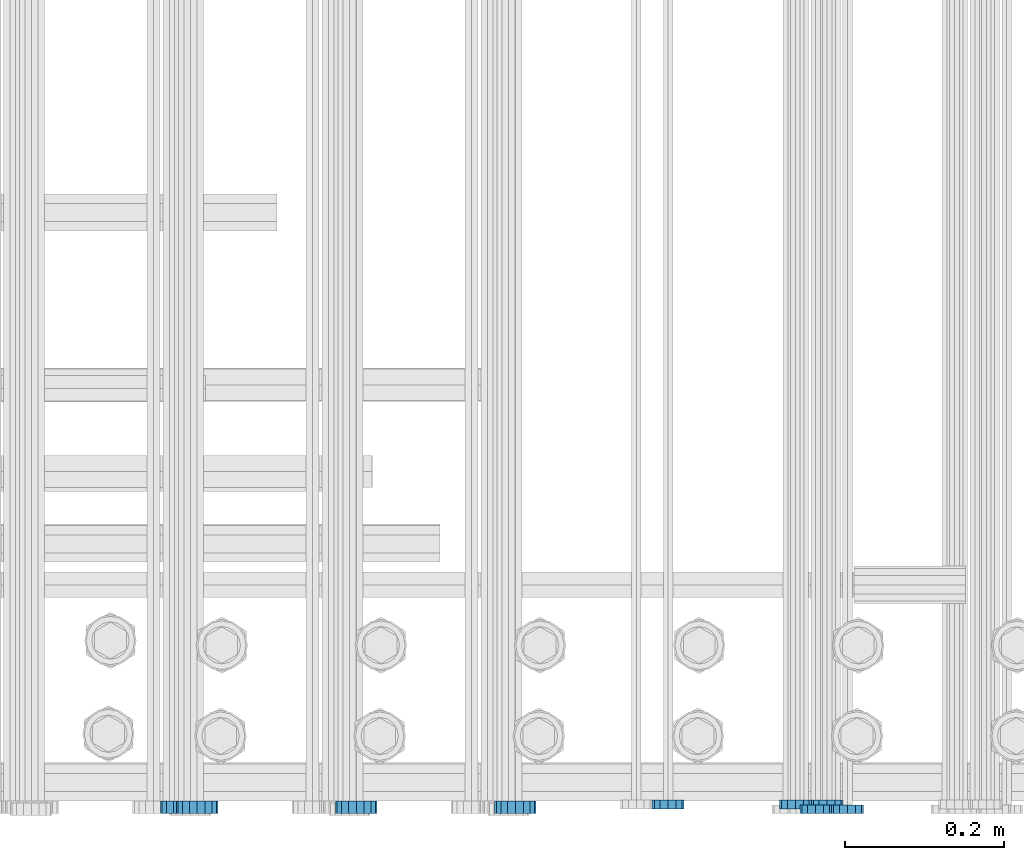
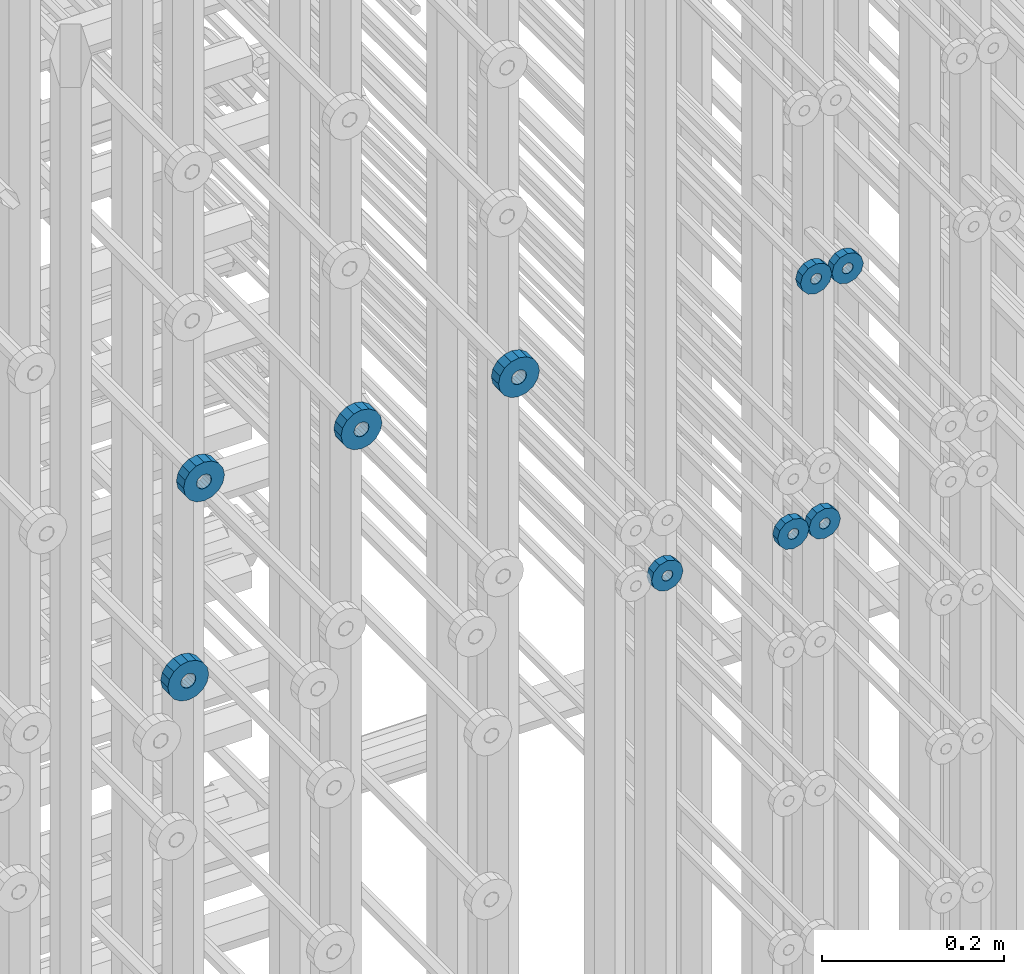
# One storey, part 121 of 177: 9 beams.
"""IFC2X3 building model written with IfcOpenShell, lengths in millimetres."""

from ifc_helpers import new_model, si_unit, frame, origin_with_axes, place, context, subcontext, project, spatial, faceted_brep, material, type_object, element, save


model = new_model("IFC2X3")

# Units and contexts
model_context_1 = context("Model", 3, precision=1e-05, world=origin_with_axes())
model_context_2 = context("Model", 3, precision=1e-05, world=origin_with_axes())
body_context = subcontext(model_context_2, "Body", "Model", "MODEL_VIEW")
ifc_project = project(units=[si_unit("LENGTHUNIT", "METRE", prefix="MILLI"), si_unit("AREAUNIT", "SQUARE_METRE"), si_unit("VOLUMEUNIT", "CUBIC_METRE"), si_unit("MASSUNIT", "GRAM", prefix="KILO"), si_unit("TIMEUNIT", "SECOND"), si_unit("PLANEANGLEUNIT", "RADIAN"), si_unit("SOLIDANGLEUNIT", "STERADIAN"), si_unit("THERMODYNAMICTEMPERATUREUNIT", "DEGREE_CELSIUS"), si_unit("LUMINOUSINTENSITYUNIT", "LUMEN")], contexts=[model_context_1])

# Site, building, storey
site_placement = place(None, origin_with_axes())
site = spatial("IfcSite", under=ifc_project, at=site_placement, CompositionType="ELEMENT")
building_placement = place(site_placement, origin_with_axes())
building = spatial("IfcBuilding", under=site, at=building_placement, Name="Undefined", CompositionType="ELEMENT")
storey_placement = place(building_placement, origin_with_axes())
storey = spatial("IfcBuildingStorey", under=building, at=storey_placement, Name="Undefined", CompositionType="ELEMENT", Elevation=0.0)

# Beams
ifc_material = material(Name="STEEL/Steel_Undefined")
beam_type_1 = type_object("IfcBeamType", PredefinedType="NOTDEFINED")
beam_1_placement = place(storey_placement, frame((2031761.99847313, 6205070.98588033, 21128.9868114202), z_axis=(0.0, 0.0, -1.0), x_axis=(0.0, -1.0, 0.0)))
element("IfcBeam", 1, at=beam_1_placement, inside=storey, type_object=beam_type_1, material=ifc_material, context=body_context, shape_type="Brep", body=[
    faceted_brep([(-3.63797880709171e-12, -7.0, -2.3283064365387e-10), (-8.62348444298797e-13, -6.06217782649107, 3.5), (10.9999999999964, -6.06217782665044, 3.49999999976717), (10.9999999999964, -7.0, -2.3283064365387e-10), (-3.63797880709171e-12, -3.5, 6.06217782618478), (11.0, -3.5, 6.06217782618478), (-1.72469688859759e-12, 0.0, 7.0), (11.0, 0.0, 6.99999999976717), (-3.63797880709171e-12, 3.5, 6.06217782618478), (11.0, 3.5, 6.06217782618478), (-8.62348444298795e-13, 6.06217782649107, 3.5), (10.9999999999964, 6.06217782665044, 3.49999999976717), (-3.63797880709171e-12, 7.0, -2.3283064365387e-10), (10.9999999999964, 7.0, -2.3283064365387e-10), (8.62348444298797e-13, 6.06217782649107, -3.5), (10.9999999999964, 6.06217782665044, -3.50000000023283), (-3.63797880709171e-12, 3.5, -6.06217782665044), (10.9999999999964, 3.5, -6.06217782665044), (1.72469688859759e-12, -2.72004641033163e-15, -7.0), (10.9999999999964, 0.0, -7.00000000023283), (-3.63797880709171e-12, -3.5, -6.06217782665044), (10.9999999999964, -3.5, -6.06217782665044), (8.62348444298796e-13, -6.06217782649107, -3.5), (10.9999999999964, -6.06217782665044, -3.50000000023283), (0.0, -20.0000000009313, 0.0), (0.0, -17.320508075878, -10.0), (10.9999999999964, -17.320508075878, -10.0000000002328), (10.9999999999964, -20.0, -2.3283064365387e-10), (0.0, -10.0000000009313, -17.3205080756452), (11.0, -10.0, -17.320508075878), (0.0, -1.86264514923096e-09, -19.9999999998836), (10.9999999999964, 0.0, -20.0000000002328), (0.0, 9.99999999906868, -17.3205080755288), (11.0, 10.0, -17.320508075878), (0.0, 17.320508075878, -10.0), (10.9999999999964, 17.320508075878, -10.0000000002328), (0.0, 19.9999999990687, 0.0), (10.9999999999964, 20.0, -2.3283064365387e-10), (0.0, 17.3205080740154, 10.0), (11.0, 17.320508075878, 9.99999999976717), (0.0, 9.99999999906868, 17.3205080757616), (10.9999999999964, 10.0, 17.3205080754124), (0.0, 0.0, 20.0000000001164), (10.9999999999964, 0.0, 19.9999999997672), (0.0, -10.0000000009313, 17.3205080757616), (10.9999999999964, -10.0, 17.3205080754124), (0.0, -17.3205080777407, 10.0000000001164), (11.0, -17.320508075878, 9.99999999976717)], [[[0, 1, 2, 3]], [[1, 4, 5, 2]], [[4, 6, 7, 5]], [[6, 8, 9, 7]], [[8, 10, 11, 9]], [[10, 12, 13, 11]], [[12, 14, 15, 13]], [[14, 16, 17, 15]], [[16, 18, 19, 17]], [[18, 20, 21, 19]], [[20, 22, 23, 21]], [[22, 0, 3, 23]], [[24, 25, 26, 27]], [[25, 28, 29, 26]], [[28, 30, 31, 29]], [[30, 32, 33, 31]], [[32, 34, 35, 33]], [[34, 36, 37, 35]], [[36, 38, 39, 37]], [[38, 40, 41, 39]], [[40, 42, 43, 41]], [[42, 44, 45, 43]], [[44, 46, 47, 45]], [[46, 24, 27, 47]], [[29, 31, 33, 35, 37, 39, 41, 43, 45, 47, 27, 26], [5, 7, 9, 11, 13, 15, 17, 19, 21, 23, 3, 2]], [[46, 44, 42, 40, 38, 36, 34, 32, 30, 28, 25, 24], [22, 20, 18, 16, 14, 12, 10, 8, 6, 4, 1, 0]]]),
])
beam_2_placement = place(storey_placement, frame((2031721.99847313, 6205070.98588033, 21128.9868114202), z_axis=(0.0, 0.0, -1.0), x_axis=(0.0, -1.0, 0.0)))
element("IfcBeam", 2, at=beam_2_placement, inside=storey, type_object=beam_type_1, material=ifc_material, context=body_context, shape_type="Brep", body=[
    faceted_brep([(-3.63797880709171e-12, -7.0, -2.3283064365387e-10), (-8.62348444298797e-13, -6.06217782649107, 3.5), (10.9999999999964, -6.06217782665044, 3.49999999976717), (10.9999999999964, -7.0, -2.3283064365387e-10), (-3.63797880709171e-12, -3.5, 6.06217782618478), (11.0, -3.5, 6.06217782618478), (-1.72469688859759e-12, 0.0, 7.0), (11.0, 0.0, 6.99999999976717), (-3.63797880709171e-12, 3.5, 6.06217782618478), (11.0, 3.5, 6.06217782618478), (-8.62348444298795e-13, 6.06217782649107, 3.5), (10.9999999999964, 6.06217782665044, 3.49999999976717), (-3.63797880709171e-12, 7.0, -2.3283064365387e-10), (10.9999999999964, 7.0, -2.3283064365387e-10), (8.62348444298797e-13, 6.06217782649107, -3.5), (10.9999999999964, 6.06217782665044, -3.50000000023283), (-3.63797880709171e-12, 3.5, -6.06217782665044), (10.9999999999964, 3.5, -6.06217782665044), (1.72469688859759e-12, -2.72004641033163e-15, -7.0), (10.9999999999964, 0.0, -7.00000000023283), (-3.63797880709171e-12, -3.5, -6.06217782665044), (10.9999999999964, -3.5, -6.06217782665044), (8.62348444298796e-13, -6.06217782649107, -3.5), (10.9999999999964, -6.06217782665044, -3.50000000023283), (0.0, -20.0000000009313, 0.0), (0.0, -17.320508075878, -10.0), (10.9999999999964, -17.320508075878, -10.0000000002328), (10.9999999999964, -20.0, -2.3283064365387e-10), (0.0, -10.0000000009313, -17.3205080756452), (11.0, -10.0, -17.320508075878), (0.0, -1.86264514923096e-09, -19.9999999998836), (10.9999999999964, 0.0, -20.0000000002328), (0.0, 9.99999999906868, -17.3205080755288), (11.0, 10.0, -17.320508075878), (0.0, 17.320508075878, -10.0), (10.9999999999964, 17.320508075878, -10.0000000002328), (0.0, 19.9999999990687, 0.0), (10.9999999999964, 20.0, -2.3283064365387e-10), (0.0, 17.3205080740154, 10.0), (11.0, 17.320508075878, 9.99999999976717), (0.0, 9.99999999906868, 17.3205080757616), (10.9999999999964, 10.0, 17.3205080754124), (0.0, 0.0, 20.0000000001164), (10.9999999999964, 0.0, 19.9999999997672), (0.0, -10.0000000009313, 17.3205080757616), (10.9999999999964, -10.0, 17.3205080754124), (0.0, -17.3205080777407, 10.0000000001164), (11.0, -17.320508075878, 9.99999999976717)], [[[0, 1, 2, 3]], [[1, 4, 5, 2]], [[4, 6, 7, 5]], [[6, 8, 9, 7]], [[8, 10, 11, 9]], [[10, 12, 13, 11]], [[12, 14, 15, 13]], [[14, 16, 17, 15]], [[16, 18, 19, 17]], [[18, 20, 21, 19]], [[20, 22, 23, 21]], [[22, 0, 3, 23]], [[24, 25, 26, 27]], [[25, 28, 29, 26]], [[28, 30, 31, 29]], [[30, 32, 33, 31]], [[32, 34, 35, 33]], [[34, 36, 37, 35]], [[36, 38, 39, 37]], [[38, 40, 41, 39]], [[40, 42, 43, 41]], [[42, 44, 45, 43]], [[44, 46, 47, 45]], [[46, 24, 27, 47]], [[29, 31, 33, 35, 37, 39, 41, 43, 45, 47, 27, 26], [5, 7, 9, 11, 13, 15, 17, 19, 21, 23, 3, 2]], [[46, 44, 42, 40, 38, 36, 34, 32, 30, 28, 25, 24], [22, 20, 18, 16, 14, 12, 10, 8, 6, 4, 1, 0]]]),
])
beam_3_placement = place(storey_placement, frame((2031736.43711754, 6205076.98588019, 20791.6768110215), z_axis=(0.0, 0.0, -1.0), x_axis=(0.0, -1.0, 0.0)))
element("IfcBeam", 3, at=beam_3_placement, inside=storey, type_object=beam_type_1, material=ifc_material, context=body_context, shape_type="Brep", body=[
    faceted_brep([(-3.63797880709171e-12, -7.0, -2.3283064365387e-10), (-8.62348444298797e-13, -6.06217782649107, 3.5), (10.9999999999964, -6.06217782665044, 3.49999999976717), (10.9999999999964, -7.0, -2.3283064365387e-10), (-3.63797880709171e-12, -3.5, 6.06217782618478), (11.0, -3.5, 6.06217782618478), (-1.72469688859759e-12, 0.0, 7.0), (11.0, 0.0, 6.99999999976717), (-3.63797880709171e-12, 3.5, 6.06217782618478), (11.0, 3.5, 6.06217782618478), (-8.62348444298795e-13, 6.06217782649107, 3.5), (10.9999999999964, 6.06217782665044, 3.49999999976717), (-3.63797880709171e-12, 7.0, -2.3283064365387e-10), (10.9999999999964, 7.0, -2.3283064365387e-10), (8.62348444298797e-13, 6.06217782649107, -3.5), (10.9999999999964, 6.06217782665044, -3.50000000023283), (-3.63797880709171e-12, 3.5, -6.06217782665044), (10.9999999999964, 3.5, -6.06217782665044), (1.72469688859759e-12, -2.72004641033163e-15, -7.0), (10.9999999999964, 0.0, -7.00000000023283), (-3.63797880709171e-12, -3.5, -6.06217782665044), (10.9999999999964, -3.5, -6.06217782665044), (8.62348444298796e-13, -6.06217782649107, -3.5), (10.9999999999964, -6.06217782665044, -3.50000000023283), (0.0, -20.0000000009313, 0.0), (0.0, -17.320508075878, -10.0), (10.9999999999964, -17.320508075878, -10.0000000002328), (10.9999999999964, -20.0, -2.3283064365387e-10), (0.0, -10.0000000009313, -17.3205080756452), (11.0, -10.0, -17.320508075878), (0.0, -1.86264514923096e-09, -19.9999999998836), (10.9999999999964, 0.0, -20.0000000002328), (0.0, 9.99999999906868, -17.3205080755288), (11.0, 10.0, -17.320508075878), (0.0, 17.320508075878, -10.0), (10.9999999999964, 17.320508075878, -10.0000000002328), (0.0, 19.9999999990687, 0.0), (10.9999999999964, 20.0, -2.3283064365387e-10), (0.0, 17.3205080740154, 10.0), (11.0, 17.320508075878, 9.99999999976717), (0.0, 9.99999999906868, 17.3205080757616), (10.9999999999964, 10.0, 17.3205080754124), (0.0, 0.0, 20.0000000001164), (10.9999999999964, 0.0, 19.9999999997672), (0.0, -10.0000000009313, 17.3205080757616), (10.9999999999964, -10.0, 17.3205080754124), (0.0, -17.3205080777407, 10.0000000001164), (11.0, -17.320508075878, 9.99999999976717)], [[[0, 1, 2, 3]], [[1, 4, 5, 2]], [[4, 6, 7, 5]], [[6, 8, 9, 7]], [[8, 10, 11, 9]], [[10, 12, 13, 11]], [[12, 14, 15, 13]], [[14, 16, 17, 15]], [[16, 18, 19, 17]], [[18, 20, 21, 19]], [[20, 22, 23, 21]], [[22, 0, 3, 23]], [[24, 25, 26, 27]], [[25, 28, 29, 26]], [[28, 30, 31, 29]], [[30, 32, 33, 31]], [[32, 34, 35, 33]], [[34, 36, 37, 35]], [[36, 38, 39, 37]], [[38, 40, 41, 39]], [[40, 42, 43, 41]], [[42, 44, 45, 43]], [[44, 46, 47, 45]], [[46, 24, 27, 47]], [[29, 31, 33, 35, 37, 39, 41, 43, 45, 47, 27, 26], [5, 7, 9, 11, 13, 15, 17, 19, 21, 23, 3, 2]], [[46, 44, 42, 40, 38, 36, 34, 32, 30, 28, 25, 24], [22, 20, 18, 16, 14, 12, 10, 8, 6, 4, 1, 0]]]),
])
beam_4_placement = place(storey_placement, frame((2031696.43711754, 6205076.98588019, 20791.6768110213), z_axis=(0.0, 0.0, -1.0), x_axis=(0.0, -1.0, 0.0)))
element("IfcBeam", 4, at=beam_4_placement, inside=storey, type_object=beam_type_1, material=ifc_material, context=body_context, shape_type="Brep", body=[
    faceted_brep([(-3.63797880709171e-12, -7.0, -2.3283064365387e-10), (-8.62348444298797e-13, -6.06217782649107, 3.5), (10.9999999999964, -6.06217782665044, 3.49999999976717), (10.9999999999964, -7.0, -2.3283064365387e-10), (-3.63797880709171e-12, -3.5, 6.06217782618478), (11.0, -3.5, 6.06217782618478), (-1.72469688859759e-12, 0.0, 7.0), (11.0, 0.0, 6.99999999976717), (-3.63797880709171e-12, 3.5, 6.06217782618478), (11.0, 3.5, 6.06217782618478), (-8.62348444298795e-13, 6.06217782649107, 3.5), (10.9999999999964, 6.06217782665044, 3.49999999976717), (-3.63797880709171e-12, 7.0, -2.3283064365387e-10), (10.9999999999964, 7.0, -2.3283064365387e-10), (8.62348444298797e-13, 6.06217782649107, -3.5), (10.9999999999964, 6.06217782665044, -3.50000000023283), (-3.63797880709171e-12, 3.5, -6.06217782665044), (10.9999999999964, 3.5, -6.06217782665044), (1.72469688859759e-12, -2.72004641033163e-15, -7.0), (10.9999999999964, 0.0, -7.00000000023283), (-3.63797880709171e-12, -3.5, -6.06217782665044), (10.9999999999964, -3.5, -6.06217782665044), (8.62348444298796e-13, -6.06217782649107, -3.5), (10.9999999999964, -6.06217782665044, -3.50000000023283), (0.0, -20.0000000009313, 0.0), (0.0, -17.320508075878, -10.0), (10.9999999999964, -17.320508075878, -10.0000000002328), (10.9999999999964, -20.0, -2.3283064365387e-10), (0.0, -10.0000000009313, -17.3205080756452), (11.0, -10.0, -17.320508075878), (0.0, -1.86264514923096e-09, -19.9999999998836), (10.9999999999964, 0.0, -20.0000000002328), (0.0, 9.99999999906868, -17.3205080755288), (11.0, 10.0, -17.320508075878), (0.0, 17.320508075878, -10.0), (10.9999999999964, 17.320508075878, -10.0000000002328), (0.0, 19.9999999990687, 0.0), (10.9999999999964, 20.0, -2.3283064365387e-10), (0.0, 17.3205080740154, 10.0), (11.0, 17.320508075878, 9.99999999976717), (0.0, 9.99999999906868, 17.3205080757616), (10.9999999999964, 10.0, 17.3205080754124), (0.0, 0.0, 20.0000000001164), (10.9999999999964, 0.0, 19.9999999997672), (0.0, -10.0000000009313, 17.3205080757616), (10.9999999999964, -10.0, 17.3205080754124), (0.0, -17.3205080777407, 10.0000000001164), (11.0, -17.320508075878, 9.99999999976717)], [[[0, 1, 2, 3]], [[1, 4, 5, 2]], [[4, 6, 7, 5]], [[6, 8, 9, 7]], [[8, 10, 11, 9]], [[10, 12, 13, 11]], [[12, 14, 15, 13]], [[14, 16, 17, 15]], [[16, 18, 19, 17]], [[18, 20, 21, 19]], [[20, 22, 23, 21]], [[22, 0, 3, 23]], [[24, 25, 26, 27]], [[25, 28, 29, 26]], [[28, 30, 31, 29]], [[30, 32, 33, 31]], [[32, 34, 35, 33]], [[34, 36, 37, 35]], [[36, 38, 39, 37]], [[38, 40, 41, 39]], [[40, 42, 43, 41]], [[42, 44, 45, 43]], [[44, 46, 47, 45]], [[46, 24, 27, 47]], [[29, 31, 33, 35, 37, 39, 41, 43, 45, 47, 27, 26], [5, 7, 9, 11, 13, 15, 17, 19, 21, 23, 3, 2]], [[46, 44, 42, 40, 38, 36, 34, 32, 30, 28, 25, 24], [22, 20, 18, 16, 14, 12, 10, 8, 6, 4, 1, 0]]]),
])
beam_5_placement = place(storey_placement, frame((2031536.43711754, 6205076.98588019, 20791.676811022), z_axis=(0.0, 0.0, -1.0), x_axis=(0.0, -1.0, 0.0)))
element("IfcBeam", 5, at=beam_5_placement, inside=storey, type_object=beam_type_1, material=ifc_material, context=body_context, shape_type="Brep", body=[
    faceted_brep([(-3.63797880709171e-12, -7.0, -2.3283064365387e-10), (-8.62348444298797e-13, -6.06217782649107, 3.5), (10.9999999999964, -6.06217782665044, 3.49999999976717), (10.9999999999964, -7.0, -2.3283064365387e-10), (-3.63797880709171e-12, -3.5, 6.06217782618478), (11.0, -3.5, 6.06217782618478), (-1.72469688859759e-12, 0.0, 7.0), (11.0, 0.0, 6.99999999976717), (-3.63797880709171e-12, 3.5, 6.06217782618478), (11.0, 3.5, 6.06217782618478), (-8.62348444298795e-13, 6.06217782649107, 3.5), (10.9999999999964, 6.06217782665044, 3.49999999976717), (-3.63797880709171e-12, 7.0, -2.3283064365387e-10), (10.9999999999964, 7.0, -2.3283064365387e-10), (8.62348444298797e-13, 6.06217782649107, -3.5), (10.9999999999964, 6.06217782665044, -3.50000000023283), (-3.63797880709171e-12, 3.5, -6.06217782665044), (10.9999999999964, 3.5, -6.06217782665044), (1.72469688859759e-12, -2.72004641033163e-15, -7.0), (10.9999999999964, 0.0, -7.00000000023283), (-3.63797880709171e-12, -3.5, -6.06217782665044), (10.9999999999964, -3.5, -6.06217782665044), (8.62348444298796e-13, -6.06217782649107, -3.5), (10.9999999999964, -6.06217782665044, -3.50000000023283), (0.0, -20.0000000009313, 0.0), (0.0, -17.320508075878, -10.0), (10.9999999999964, -17.320508075878, -10.0000000002328), (10.9999999999964, -20.0, -2.3283064365387e-10), (0.0, -10.0000000009313, -17.3205080756452), (11.0, -10.0, -17.320508075878), (0.0, -1.86264514923096e-09, -19.9999999998836), (10.9999999999964, 0.0, -20.0000000002328), (0.0, 9.99999999906868, -17.3205080755288), (11.0, 10.0, -17.320508075878), (0.0, 17.320508075878, -10.0), (10.9999999999964, 17.320508075878, -10.0000000002328), (0.0, 19.9999999990687, 0.0), (10.9999999999964, 20.0, -2.3283064365387e-10), (0.0, 17.3205080740154, 10.0), (11.0, 17.320508075878, 9.99999999976717), (0.0, 9.99999999906868, 17.3205080757616), (10.9999999999964, 10.0, 17.3205080754124), (0.0, 0.0, 20.0000000001164), (10.9999999999964, 0.0, 19.9999999997672), (0.0, -10.0000000009313, 17.3205080757616), (10.9999999999964, -10.0, 17.3205080754124), (0.0, -17.3205080777407, 10.0000000001164), (11.0, -17.320508075878, 9.99999999976717)], [[[0, 1, 2, 3]], [[1, 4, 5, 2]], [[4, 6, 7, 5]], [[6, 8, 9, 7]], [[8, 10, 11, 9]], [[10, 12, 13, 11]], [[12, 14, 15, 13]], [[14, 16, 17, 15]], [[16, 18, 19, 17]], [[18, 20, 21, 19]], [[20, 22, 23, 21]], [[22, 0, 3, 23]], [[24, 25, 26, 27]], [[25, 28, 29, 26]], [[28, 30, 31, 29]], [[30, 32, 33, 31]], [[32, 34, 35, 33]], [[34, 36, 37, 35]], [[36, 38, 39, 37]], [[38, 40, 41, 39]], [[40, 42, 43, 41]], [[42, 44, 45, 43]], [[44, 46, 47, 45]], [[46, 24, 27, 47]], [[29, 31, 33, 35, 37, 39, 41, 43, 45, 47, 27, 26], [5, 7, 9, 11, 13, 15, 17, 19, 21, 23, 3, 2]], [[46, 44, 42, 40, 38, 36, 34, 32, 30, 28, 25, 24], [22, 20, 18, 16, 14, 12, 10, 8, 6, 4, 1, 0]]]),
])
beam_type_2 = type_object("IfcBeamType", PredefinedType="NOTDEFINED")
beam_6_placement = place(storey_placement, frame((2030924.49847313, 6205075.98588568, 20868.4868124752), z_axis=(0.0, 0.0, -1.0), x_axis=(0.0, -1.0, 0.0)))
element("IfcBeam", 6, at=beam_6_placement, inside=storey, type_object=beam_type_2, material=ifc_material, context=body_context, shape_type="Brep", body=[
    faceted_brep([(0.0, -9.5, 0.0), (0.0, -8.77685555908829, 3.63549260746731), (16.0, -8.77685555908829, 3.63549260746731), (16.0, -9.5, 0.0), (0.0, -6.71751442085952, 6.71751442127061), (16.0, -6.71751442085952, 6.71751442127061), (0.0, -3.63549260701984, 8.77685555885546), (16.0, -3.63549260701984, 8.77685555885546), (-2.02452244836415e-12, 0.0, 9.5), (16.0, 0.0, 9.5), (0.0, 3.63549260701984, 8.77685555885546), (16.0, 3.63549260701984, 8.77685555885546), (0.0, 6.71751442085952, 6.71751442127061), (16.0, 6.71751442085952, 6.71751442127061), (0.0, 8.77685555908829, 3.63549260746731), (16.0, 8.77685555908829, 3.63549260746731), (0.0, 9.5, 0.0), (16.0, 9.5, 0.0), (0.0, 8.77685555908829, -3.63549260746731), (16.0, 8.77685555908829, -3.63549260746731), (0.0, 6.71751442085952, -6.71751442127061), (16.0, 6.71751442085952, -6.71751442127061), (0.0, 3.63549260701984, -8.77685555885546), (16.0, 3.63549260701984, -8.77685555885546), (2.02452244836415e-12, -3.69149155687865e-15, -9.5), (16.0, 0.0, -9.5), (0.0, -3.63549260701984, -8.77685555885546), (16.0, -3.63549260701984, -8.77685555885546), (0.0, -6.71751442085952, -6.71751442127061), (16.0, -6.71751442085952, -6.71751442127061), (0.0, -8.77685555908829, -3.63549260746731), (16.0, -8.77685555908829, -3.63549260746731), (0.0, -26.0, 0.0), (0.0, -24.0208678450435, -9.94976924149159), (16.0, -24.0208678450435, -9.94976924149159), (16.0, -26.0, 0.0), (0.0, -18.3847763109952, -18.3847763108497), (16.0, -18.3847763109952, -18.3847763108497), (0.0, -9.94976924173534, -24.0208678452946), (16.0, -9.94976924173534, -24.0208678452946), (0.0, 0.0, -26.0), (16.0, 0.0, -26.0), (0.0, 9.94976924173534, -24.0208678452946), (16.0, 9.94976924173534, -24.0208678452946), (0.0, 18.3847763109952, -18.3847763108497), (16.0, 18.3847763109952, -18.3847763108497), (0.0, 24.0208678450435, -9.94976924149159), (16.0, 24.0208678450435, -9.94976924149159), (0.0, 26.0, 0.0), (16.0, 26.0, 0.0), (0.0, 24.0208678450435, 9.94976924149159), (16.0, 24.0208678450435, 9.94976924149159), (0.0, 18.3847763109952, 18.3847763108497), (16.0, 18.3847763109952, 18.3847763108497), (0.0, 9.94976924173534, 24.0208678452946), (16.0, 9.94976924173534, 24.0208678452946), (0.0, 0.0, 26.0), (16.0, 0.0, 26.0), (0.0, -9.94976924173534, 24.0208678452946), (16.0, -9.94976924173534, 24.0208678452946), (0.0, -18.3847763109952, 18.3847763108497), (16.0, -18.3847763109952, 18.3847763108497), (0.0, -24.0208678450435, 9.94976924149159), (16.0, -24.0208678450435, 9.94976924149159)], [[[0, 1, 2, 3]], [[1, 4, 5, 2]], [[4, 6, 7, 5]], [[6, 8, 9, 7]], [[8, 10, 11, 9]], [[10, 12, 13, 11]], [[12, 14, 15, 13]], [[14, 16, 17, 15]], [[16, 18, 19, 17]], [[18, 20, 21, 19]], [[20, 22, 23, 21]], [[22, 24, 25, 23]], [[24, 26, 27, 25]], [[26, 28, 29, 27]], [[28, 30, 31, 29]], [[30, 0, 3, 31]], [[32, 33, 34, 35]], [[33, 36, 37, 34]], [[36, 38, 39, 37]], [[38, 40, 41, 39]], [[40, 42, 43, 41]], [[42, 44, 45, 43]], [[44, 46, 47, 45]], [[46, 48, 49, 47]], [[48, 50, 51, 49]], [[50, 52, 53, 51]], [[52, 54, 55, 53]], [[54, 56, 57, 55]], [[56, 58, 59, 57]], [[58, 60, 61, 59]], [[60, 62, 63, 61]], [[62, 32, 35, 63]], [[37, 39, 41, 43, 45, 47, 49, 51, 53, 55, 57, 59, 61, 63, 35, 34], [5, 7, 9, 11, 13, 15, 17, 19, 21, 23, 25, 27, 29, 31, 3, 2]], [[62, 60, 58, 56, 54, 52, 50, 48, 46, 44, 42, 40, 38, 36, 33, 32], [30, 28, 26, 24, 22, 20, 18, 16, 14, 12, 10, 8, 6, 4, 1, 0]]]),
])
beam_7_placement = place(storey_placement, frame((2031344.49847313, 6205075.98588578, 21128.9868125736), z_axis=(0.0, 0.0, -1.0), x_axis=(0.0, -1.0, 0.0)))
element("IfcBeam", 7, at=beam_7_placement, inside=storey, type_object=beam_type_2, material=ifc_material, context=body_context, shape_type="Brep", body=[
    faceted_brep([(0.0, -9.5, 0.0), (0.0, -8.77685555908829, 3.63549260746731), (16.0, -8.77685555908829, 3.63549260746731), (16.0, -9.5, 0.0), (0.0, -6.71751442085952, 6.71751442127061), (16.0, -6.71751442085952, 6.71751442127061), (0.0, -3.63549260701984, 8.77685555885546), (16.0, -3.63549260701984, 8.77685555885546), (-2.02452244836415e-12, 0.0, 9.5), (16.0, 0.0, 9.5), (0.0, 3.63549260701984, 8.77685555885546), (16.0, 3.63549260701984, 8.77685555885546), (0.0, 6.71751442085952, 6.71751442127061), (16.0, 6.71751442085952, 6.71751442127061), (0.0, 8.77685555908829, 3.63549260746731), (16.0, 8.77685555908829, 3.63549260746731), (0.0, 9.5, 0.0), (16.0, 9.5, 0.0), (0.0, 8.77685555908829, -3.63549260746731), (16.0, 8.77685555908829, -3.63549260746731), (0.0, 6.71751442085952, -6.71751442127061), (16.0, 6.71751442085952, -6.71751442127061), (0.0, 3.63549260701984, -8.77685555885546), (16.0, 3.63549260701984, -8.77685555885546), (2.02452244836415e-12, -3.69149155687865e-15, -9.5), (16.0, 0.0, -9.5), (0.0, -3.63549260701984, -8.77685555885546), (16.0, -3.63549260701984, -8.77685555885546), (0.0, -6.71751442085952, -6.71751442127061), (16.0, -6.71751442085952, -6.71751442127061), (0.0, -8.77685555908829, -3.63549260746731), (16.0, -8.77685555908829, -3.63549260746731), (0.0, -26.0, 0.0), (0.0, -24.0208678450435, -9.94976924149159), (16.0, -24.0208678450435, -9.94976924149159), (16.0, -26.0, 0.0), (0.0, -18.3847763109952, -18.3847763108497), (16.0, -18.3847763109952, -18.3847763108497), (0.0, -9.94976924173534, -24.0208678452946), (16.0, -9.94976924173534, -24.0208678452946), (0.0, 0.0, -26.0), (16.0, 0.0, -26.0), (0.0, 9.94976924173534, -24.0208678452946), (16.0, 9.94976924173534, -24.0208678452946), (0.0, 18.3847763109952, -18.3847763108497), (16.0, 18.3847763109952, -18.3847763108497), (0.0, 24.0208678450435, -9.94976924149159), (16.0, 24.0208678450435, -9.94976924149159), (0.0, 26.0, 0.0), (16.0, 26.0, 0.0), (0.0, 24.0208678450435, 9.94976924149159), (16.0, 24.0208678450435, 9.94976924149159), (0.0, 18.3847763109952, 18.3847763108497), (16.0, 18.3847763109952, 18.3847763108497), (0.0, 9.94976924173534, 24.0208678452946), (16.0, 9.94976924173534, 24.0208678452946), (0.0, 0.0, 26.0), (16.0, 0.0, 26.0), (0.0, -9.94976924173534, 24.0208678452946), (16.0, -9.94976924173534, 24.0208678452946), (0.0, -18.3847763109952, 18.3847763108497), (16.0, -18.3847763109952, 18.3847763108497), (0.0, -24.0208678450435, 9.94976924149159), (16.0, -24.0208678450435, 9.94976924149159)], [[[0, 1, 2, 3]], [[1, 4, 5, 2]], [[4, 6, 7, 5]], [[6, 8, 9, 7]], [[8, 10, 11, 9]], [[10, 12, 13, 11]], [[12, 14, 15, 13]], [[14, 16, 17, 15]], [[16, 18, 19, 17]], [[18, 20, 21, 19]], [[20, 22, 23, 21]], [[22, 24, 25, 23]], [[24, 26, 27, 25]], [[26, 28, 29, 27]], [[28, 30, 31, 29]], [[30, 0, 3, 31]], [[32, 33, 34, 35]], [[33, 36, 37, 34]], [[36, 38, 39, 37]], [[38, 40, 41, 39]], [[40, 42, 43, 41]], [[42, 44, 45, 43]], [[44, 46, 47, 45]], [[46, 48, 49, 47]], [[48, 50, 51, 49]], [[50, 52, 53, 51]], [[52, 54, 55, 53]], [[54, 56, 57, 55]], [[56, 58, 59, 57]], [[58, 60, 61, 59]], [[60, 62, 63, 61]], [[62, 32, 35, 63]], [[37, 39, 41, 43, 45, 47, 49, 51, 53, 55, 57, 59, 61, 63, 35, 34], [5, 7, 9, 11, 13, 15, 17, 19, 21, 23, 25, 27, 29, 31, 3, 2]], [[62, 60, 58, 56, 54, 52, 50, 48, 46, 44, 42, 40, 38, 36, 33, 32], [30, 28, 26, 24, 22, 20, 18, 16, 14, 12, 10, 8, 6, 4, 1, 0]]]),
])
beam_8_placement = place(storey_placement, frame((2031144.49847313, 6205075.98588578, 21128.9868125736), z_axis=(0.0, 0.0, -1.0), x_axis=(0.0, -1.0, 0.0)))
element("IfcBeam", 8, at=beam_8_placement, inside=storey, type_object=beam_type_2, material=ifc_material, context=body_context, shape_type="Brep", body=[
    faceted_brep([(0.0, -9.5, 0.0), (0.0, -8.77685555908829, 3.63549260746731), (16.0, -8.77685555908829, 3.63549260746731), (16.0, -9.5, 0.0), (0.0, -6.71751442085952, 6.71751442127061), (16.0, -6.71751442085952, 6.71751442127061), (0.0, -3.63549260701984, 8.77685555885546), (16.0, -3.63549260701984, 8.77685555885546), (-2.02452244836415e-12, 0.0, 9.5), (16.0, 0.0, 9.5), (0.0, 3.63549260701984, 8.77685555885546), (16.0, 3.63549260701984, 8.77685555885546), (0.0, 6.71751442085952, 6.71751442127061), (16.0, 6.71751442085952, 6.71751442127061), (0.0, 8.77685555908829, 3.63549260746731), (16.0, 8.77685555908829, 3.63549260746731), (0.0, 9.5, 0.0), (16.0, 9.5, 0.0), (0.0, 8.77685555908829, -3.63549260746731), (16.0, 8.77685555908829, -3.63549260746731), (0.0, 6.71751442085952, -6.71751442127061), (16.0, 6.71751442085952, -6.71751442127061), (0.0, 3.63549260701984, -8.77685555885546), (16.0, 3.63549260701984, -8.77685555885546), (2.02452244836415e-12, -3.69149155687865e-15, -9.5), (16.0, 0.0, -9.5), (0.0, -3.63549260701984, -8.77685555885546), (16.0, -3.63549260701984, -8.77685555885546), (0.0, -6.71751442085952, -6.71751442127061), (16.0, -6.71751442085952, -6.71751442127061), (0.0, -8.77685555908829, -3.63549260746731), (16.0, -8.77685555908829, -3.63549260746731), (0.0, -26.0, 0.0), (0.0, -24.0208678450435, -9.94976924149159), (16.0, -24.0208678450435, -9.94976924149159), (16.0, -26.0, 0.0), (0.0, -18.3847763109952, -18.3847763108497), (16.0, -18.3847763109952, -18.3847763108497), (0.0, -9.94976924173534, -24.0208678452946), (16.0, -9.94976924173534, -24.0208678452946), (0.0, 0.0, -26.0), (16.0, 0.0, -26.0), (0.0, 9.94976924173534, -24.0208678452946), (16.0, 9.94976924173534, -24.0208678452946), (0.0, 18.3847763109952, -18.3847763108497), (16.0, 18.3847763109952, -18.3847763108497), (0.0, 24.0208678450435, -9.94976924149159), (16.0, 24.0208678450435, -9.94976924149159), (0.0, 26.0, 0.0), (16.0, 26.0, 0.0), (0.0, 24.0208678450435, 9.94976924149159), (16.0, 24.0208678450435, 9.94976924149159), (0.0, 18.3847763109952, 18.3847763108497), (16.0, 18.3847763109952, 18.3847763108497), (0.0, 9.94976924173534, 24.0208678452946), (16.0, 9.94976924173534, 24.0208678452946), (0.0, 0.0, 26.0), (16.0, 0.0, 26.0), (0.0, -9.94976924173534, 24.0208678452946), (16.0, -9.94976924173534, 24.0208678452946), (0.0, -18.3847763109952, 18.3847763108497), (16.0, -18.3847763109952, 18.3847763108497), (0.0, -24.0208678450435, 9.94976924149159), (16.0, -24.0208678450435, 9.94976924149159)], [[[0, 1, 2, 3]], [[1, 4, 5, 2]], [[4, 6, 7, 5]], [[6, 8, 9, 7]], [[8, 10, 11, 9]], [[10, 12, 13, 11]], [[12, 14, 15, 13]], [[14, 16, 17, 15]], [[16, 18, 19, 17]], [[18, 20, 21, 19]], [[20, 22, 23, 21]], [[22, 24, 25, 23]], [[24, 26, 27, 25]], [[26, 28, 29, 27]], [[28, 30, 31, 29]], [[30, 0, 3, 31]], [[32, 33, 34, 35]], [[33, 36, 37, 34]], [[36, 38, 39, 37]], [[38, 40, 41, 39]], [[40, 42, 43, 41]], [[42, 44, 45, 43]], [[44, 46, 47, 45]], [[46, 48, 49, 47]], [[48, 50, 51, 49]], [[50, 52, 53, 51]], [[52, 54, 55, 53]], [[54, 56, 57, 55]], [[56, 58, 59, 57]], [[58, 60, 61, 59]], [[60, 62, 63, 61]], [[62, 32, 35, 63]], [[37, 39, 41, 43, 45, 47, 49, 51, 53, 55, 57, 59, 61, 63, 35, 34], [5, 7, 9, 11, 13, 15, 17, 19, 21, 23, 25, 27, 29, 31, 3, 2]], [[62, 60, 58, 56, 54, 52, 50, 48, 46, 44, 42, 40, 38, 36, 33, 32], [30, 28, 26, 24, 22, 20, 18, 16, 14, 12, 10, 8, 6, 4, 1, 0]]]),
])
beam_9_placement = place(storey_placement, frame((2030944.49847313, 6205075.98588578, 21128.9868125736), z_axis=(0.0, 0.0, -1.0), x_axis=(0.0, -1.0, 0.0)))
element("IfcBeam", 9, at=beam_9_placement, inside=storey, type_object=beam_type_2, material=ifc_material, context=body_context, shape_type="Brep", body=[
    faceted_brep([(0.0, -9.5, 0.0), (0.0, -8.77685555908829, 3.63549260746731), (16.0, -8.77685555908829, 3.63549260746731), (16.0, -9.5, 0.0), (0.0, -6.71751442085952, 6.71751442127061), (16.0, -6.71751442085952, 6.71751442127061), (0.0, -3.63549260701984, 8.77685555885546), (16.0, -3.63549260701984, 8.77685555885546), (-2.02452244836415e-12, 0.0, 9.5), (16.0, 0.0, 9.5), (0.0, 3.63549260701984, 8.77685555885546), (16.0, 3.63549260701984, 8.77685555885546), (0.0, 6.71751442085952, 6.71751442127061), (16.0, 6.71751442085952, 6.71751442127061), (0.0, 8.77685555908829, 3.63549260746731), (16.0, 8.77685555908829, 3.63549260746731), (0.0, 9.5, 0.0), (16.0, 9.5, 0.0), (0.0, 8.77685555908829, -3.63549260746731), (16.0, 8.77685555908829, -3.63549260746731), (0.0, 6.71751442085952, -6.71751442127061), (16.0, 6.71751442085952, -6.71751442127061), (0.0, 3.63549260701984, -8.77685555885546), (16.0, 3.63549260701984, -8.77685555885546), (2.02452244836415e-12, -3.69149155687865e-15, -9.5), (16.0, 0.0, -9.5), (0.0, -3.63549260701984, -8.77685555885546), (16.0, -3.63549260701984, -8.77685555885546), (0.0, -6.71751442085952, -6.71751442127061), (16.0, -6.71751442085952, -6.71751442127061), (0.0, -8.77685555908829, -3.63549260746731), (16.0, -8.77685555908829, -3.63549260746731), (0.0, -26.0, 0.0), (0.0, -24.0208678450435, -9.94976924149159), (16.0, -24.0208678450435, -9.94976924149159), (16.0, -26.0, 0.0), (0.0, -18.3847763109952, -18.3847763108497), (16.0, -18.3847763109952, -18.3847763108497), (0.0, -9.94976924173534, -24.0208678452946), (16.0, -9.94976924173534, -24.0208678452946), (0.0, 0.0, -26.0), (16.0, 0.0, -26.0), (0.0, 9.94976924173534, -24.0208678452946), (16.0, 9.94976924173534, -24.0208678452946), (0.0, 18.3847763109952, -18.3847763108497), (16.0, 18.3847763109952, -18.3847763108497), (0.0, 24.0208678450435, -9.94976924149159), (16.0, 24.0208678450435, -9.94976924149159), (0.0, 26.0, 0.0), (16.0, 26.0, 0.0), (0.0, 24.0208678450435, 9.94976924149159), (16.0, 24.0208678450435, 9.94976924149159), (0.0, 18.3847763109952, 18.3847763108497), (16.0, 18.3847763109952, 18.3847763108497), (0.0, 9.94976924173534, 24.0208678452946), (16.0, 9.94976924173534, 24.0208678452946), (0.0, 0.0, 26.0), (16.0, 0.0, 26.0), (0.0, -9.94976924173534, 24.0208678452946), (16.0, -9.94976924173534, 24.0208678452946), (0.0, -18.3847763109952, 18.3847763108497), (16.0, -18.3847763109952, 18.3847763108497), (0.0, -24.0208678450435, 9.94976924149159), (16.0, -24.0208678450435, 9.94976924149159)], [[[0, 1, 2, 3]], [[1, 4, 5, 2]], [[4, 6, 7, 5]], [[6, 8, 9, 7]], [[8, 10, 11, 9]], [[10, 12, 13, 11]], [[12, 14, 15, 13]], [[14, 16, 17, 15]], [[16, 18, 19, 17]], [[18, 20, 21, 19]], [[20, 22, 23, 21]], [[22, 24, 25, 23]], [[24, 26, 27, 25]], [[26, 28, 29, 27]], [[28, 30, 31, 29]], [[30, 0, 3, 31]], [[32, 33, 34, 35]], [[33, 36, 37, 34]], [[36, 38, 39, 37]], [[38, 40, 41, 39]], [[40, 42, 43, 41]], [[42, 44, 45, 43]], [[44, 46, 47, 45]], [[46, 48, 49, 47]], [[48, 50, 51, 49]], [[50, 52, 53, 51]], [[52, 54, 55, 53]], [[54, 56, 57, 55]], [[56, 58, 59, 57]], [[58, 60, 61, 59]], [[60, 62, 63, 61]], [[62, 32, 35, 63]], [[37, 39, 41, 43, 45, 47, 49, 51, 53, 55, 57, 59, 61, 63, 35, 34], [5, 7, 9, 11, 13, 15, 17, 19, 21, 23, 25, 27, 29, 31, 3, 2]], [[62, 60, 58, 56, 54, 52, 50, 48, 46, 44, 42, 40, 38, 36, 33, 32], [30, 28, 26, 24, 22, 20, 18, 16, 14, 12, 10, 8, 6, 4, 1, 0]]]),
])

save(model, "model.ifc")
